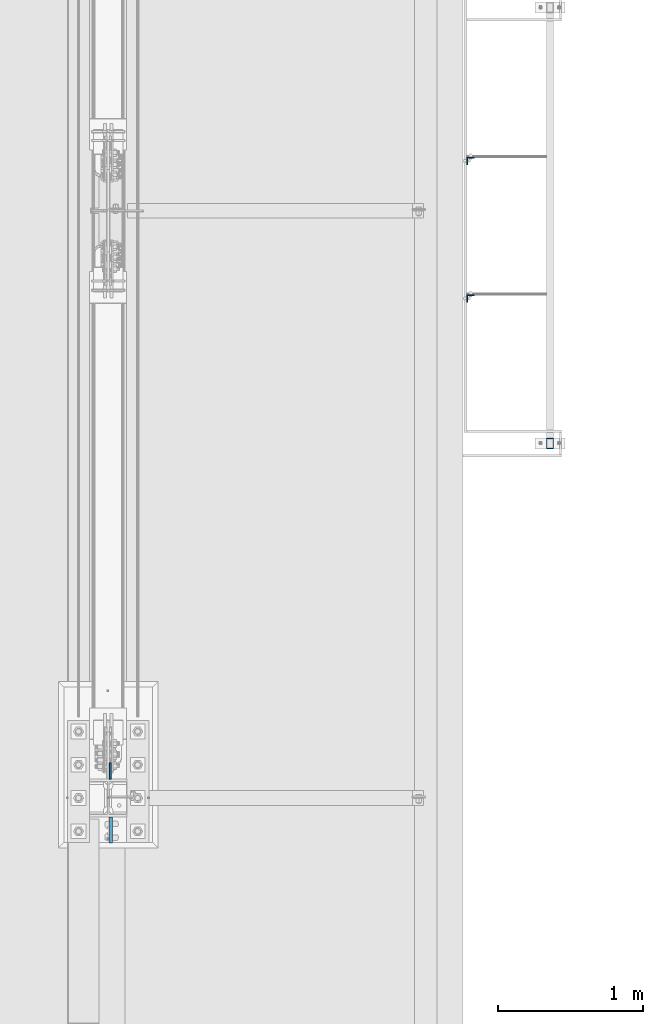
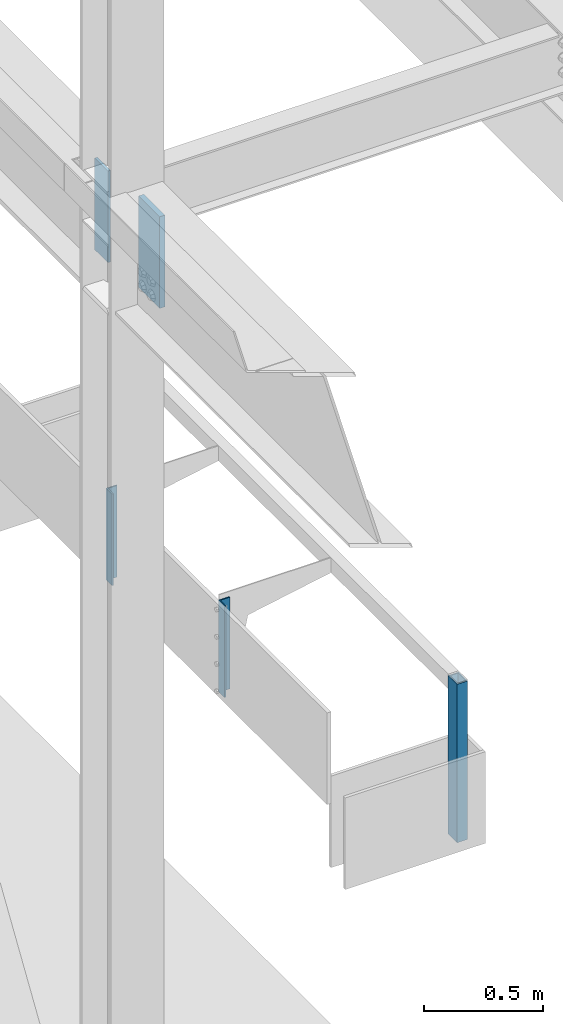
# One storey, part 1540 of 3843: 5 columns, 4 elements without a shape of their own.
"""IFC2X3 building model written with IfcOpenShell, lengths in millimetres."""

import ifcopenshell
import ifcopenshell.guid

model = None  # the IFC model being written
_history = None  # IfcOwnerHistory: only IFC2X3 demands one
_inside = {}  # id of a spatial element -> (the spatial element, [elements in it])
_under = {}  # id of a project, library or spatial element -> (it, [spatial elements below it])
_declared = {}  # id of a project -> (the project, [libraries it declares])
_typed = {}  # id of a type object -> (the type object, [elements of that type])
_made_of = {}  # id of a material, layer set ... -> (it, [elements and type objects made of it])


def new_model(schema):
    """Start an empty IFC model of exactly this schema.

    Asked for "IFC4X3", IfcOpenShell would pick the latest addendum, in which some entities
    have other attributes; the version numbers below select the first issue.
    IFC2X3 requires an IfcOwnerHistory on every rooted entity: one is made here for all.
    """
    global model, _history
    if schema == "IFC4X3":
        model = ifcopenshell.file(schema_version=(4, 3, 0, 0))
    else:
        model = ifcopenshell.file(schema=schema)
    _inside.clear()
    _under.clear()
    _declared.clear()
    _typed.clear()
    _made_of.clear()
    _history = None
    if model.schema == "IFC2X3":
        org = make("IfcOrganization", Name="unknown")
        user = make(
            "IfcPersonAndOrganization",
            ThePerson=make("IfcPerson", FamilyName="unknown"),
            TheOrganization=org,
        )
        app = make(
            "IfcApplication",
            ApplicationDeveloper=org,
            Version="unknown",
            ApplicationFullName="unknown",
            ApplicationIdentifier="unknown",
        )
        _history = make(
            "IfcOwnerHistory",
            OwningUser=user,
            OwningApplication=app,
            ChangeAction="ADDED",
            CreationDate=0,
        )
    return model


def make(cls, **values):
    """One entity of the class cls with the attributes given. An attribute that is None is left unset."""
    return model.create_entity(
        cls, **{name: value for name, value in values.items() if value is not None}
    )


def rooted(cls, **values):
    """An entity with a GlobalId (a new one), such as an element, a storey or a relation."""
    return make(cls, GlobalId=ifcopenshell.guid.new(), OwnerHistory=_history, **values)


def si_unit(unit_type, name, prefix=None):
    """IfcSIUnit, for example si_unit("LENGTHUNIT", "METRE", prefix="MILLI")."""
    return make("IfcSIUnit", UnitType=unit_type, Prefix=prefix, Name=name)


def assignment(units):
    """IfcUnitAssignment: the units of a project."""
    return None if units is None else make("IfcUnitAssignment", Units=units)


def point(xyz):
    """IfcCartesianPoint."""
    return None if xyz is None else make("IfcCartesianPoint", Coordinates=xyz)


def direction(xyz):
    """IfcDirection."""
    return None if xyz is None else make("IfcDirection", DirectionRatios=xyz)


def frame(location, z_axis=None, x_axis=None):
    """IfcAxis2Placement3D, a coordinate frame: its origin and axes. An axis left out is left unset."""
    return make(
        "IfcAxis2Placement3D",
        Location=point(location),
        Axis=direction(z_axis),
        RefDirection=direction(x_axis),
    )


def origin_with_axes():
    """The frame at (0, 0, 0) with the z axis (0, 0, 1) and the x axis (1, 0, 0) written out."""
    return frame((0.0, 0.0, 0.0), z_axis=(0.0, 0.0, 1.0), x_axis=(1.0, 0.0, 0.0))


def place(relative_to, where):
    """IfcLocalPlacement: puts the frame where relative to a parent placement (None: the world)."""
    return make(
        "IfcLocalPlacement", PlacementRelTo=relative_to, RelativePlacement=where
    )


def context(
    kind, dimensions, precision=None, world=None, true_north=None, identifier=None
):
    """IfcGeometricRepresentationContext, for example the 3D "Model" context."""
    return make(
        "IfcGeometricRepresentationContext",
        ContextIdentifier=identifier,
        ContextType=kind,
        CoordinateSpaceDimension=dimensions,
        Precision=precision,
        WorldCoordinateSystem=world,
        TrueNorth=true_north,
    )


def subcontext(parent, identifier, kind, view, scale=None):
    """IfcGeometricRepresentationSubContext, for example "Body" below "Model"."""
    return make(
        "IfcGeometricRepresentationSubContext",
        ContextIdentifier=identifier,
        ContextType=kind,
        ParentContext=parent,
        TargetScale=scale,
        TargetView=view,
    )


def project(units=None, contexts=None):
    """IfcProject with its units and contexts."""
    return rooted(
        "IfcProject",
        Name="project",
        RepresentationContexts=contexts,
        UnitsInContext=assignment(units),
    )


def spatial(cls, under=None, at=None, **own):
    """A site, building, storey or space (cls), placed at a placement, below another one or the project."""
    s = rooted(cls, ObjectPlacement=at, **own)
    if under is not None:
        _under.setdefault(under.id(), (under, []))[1].append(s)
    return s


def faces_of(points, faces, orient=None, outer=None):
    """IfcFace entities. A face is a list of loops; a loop is a list of indices into points, from 0.

    orient and outer hold one flag for each loop. By default every Orientation is true, the
    first loop of a face is its IfcFaceOuterBound and the others are IfcFaceBound.
    """
    made = []
    for i, loops in enumerate(faces):
        bounds = []
        for j, loop in enumerate(loops):
            is_outer = j == 0 if outer is None else outer[i][j]
            bounds.append(
                make(
                    "IfcFaceOuterBound" if is_outer else "IfcFaceBound",
                    Bound=make("IfcPolyLoop", Polygon=[points[k] for k in loop]),
                    Orientation=True if orient is None else orient[i][j],
                )
            )
        made.append(make("IfcFace", Bounds=bounds))
    return made


def faceted_brep(points, faces, orient=None, outer=None, voids=None):
    """IfcFacetedBrep: a solid bounded by flat faces; with voids (closed shells), ...WithVoids."""
    shared = [point(p) for p in points]
    hull = make("IfcClosedShell", CfsFaces=faces_of(shared, faces, orient, outer))
    if voids is None:
        return make("IfcFacetedBrep", Outer=hull)
    return make(
        "IfcFacetedBrepWithVoids",
        Outer=hull,
        Voids=[
            make(cls, CfsFaces=faces_of(shared, fs, o, b)) for cls, fs, o, b in voids
        ],
    )


def shape(context_of_items, identifier, shape_type, items):
    """IfcShapeRepresentation: the items that make up one representation, for example the "Body"."""
    return make(
        "IfcShapeRepresentation",
        ContextOfItems=context_of_items,
        RepresentationIdentifier=identifier,
        RepresentationType=shape_type,
        Items=items,
    )


def material(Name=None, Category=None):
    """IfcMaterial."""
    return make("IfcMaterial", Name=Name, Category=Category)


def made_of(thing, what):
    """Note that an element or type object is made of a material, layer set ...; save() writes the relation."""
    if what is not None:
        _made_of.setdefault(what.id(), (what, []))[1].append(thing)
    return thing


def type_object(cls, material=None, **own):
    """A type object (cls), such as IfcWallType, which elements share."""
    return made_of(rooted(cls, **own), material)


def element(
    cls,
    number,
    at=None,
    inside=None,
    cuts=None,
    type_object=None,
    material=None,
    context=None,
    identifier="Body",
    shape_type=None,
    held_by="IfcProductDefinitionShape",
    body=None,
    shapes=None,
    **own,
):
    """One element of the class cls, such as IfcWall. Its Tag is "e" and its number.

    at: its placement. inside: the storey or other place that contains it. cuts: it is an
    opening in that element (IfcRelVoidsElement). A single representation is given by context,
    identifier, shape_type and body (its items); several are given by shapes. held_by: the class
    of the entity that holds the representations. save() writes the other relations.
    """
    e = rooted(cls, Tag="e%d" % number, ObjectPlacement=at, **own)
    if body is not None:
        shapes = [shape(context, identifier, shape_type, body)]
    if shapes is not None:
        e.Representation = make(held_by, Representations=shapes)
    if inside is not None:
        _inside.setdefault(inside.id(), (inside, []))[1].append(e)
    if cuts is not None:
        rooted(
            "IfcRelVoidsElement", RelatingBuildingElement=cuts, RelatedOpeningElement=e
        )
    if type_object is not None:
        _typed.setdefault(type_object.id(), (type_object, []))[1].append(e)
    return made_of(e, material)


def aggregate(whole, parts):
    """IfcRelAggregates: a whole, such as a stair, and the parts it consists of."""
    return rooted("IfcRelAggregates", RelatingObject=whole, RelatedObjects=parts)


def save(model, path):
    """Write the relations noted so far, then the file.

    IfcRelAggregates (storeys below a building ...), IfcRelContainedInSpatialStructure (elements
    in a storey), IfcRelDefinesByType, IfcRelAssociatesMaterial and IfcRelDeclares: one each for
    every whole, place, type object, material and project.
    """
    for whole, parts in _under.values():
        aggregate(whole, parts)
    for where, things in _inside.values():
        rooted(
            "IfcRelContainedInSpatialStructure",
            RelatedElements=things,
            RelatingStructure=where,
        )
    for kind, things in _typed.values():
        rooted("IfcRelDefinesByType", RelatedObjects=things, RelatingType=kind)
    for what, things in _made_of.values():
        rooted("IfcRelAssociatesMaterial", RelatedObjects=things, RelatingMaterial=what)
    for by, libraries in _declared.values():
        rooted("IfcRelDeclares", RelatingContext=by, RelatedDefinitions=libraries)
    model.write(path)


model = new_model("IFC2X3")

# Units and contexts
model_context = context("Model", 3, precision=1e-05, world=origin_with_axes())
body_context = subcontext(model_context, "Body", "Model", "MODEL_VIEW")
ifc_project = project(units=[si_unit("LENGTHUNIT", "METRE", prefix="MILLI"), si_unit("AREAUNIT", "SQUARE_METRE"), si_unit("VOLUMEUNIT", "CUBIC_METRE"), si_unit("MASSUNIT", "GRAM", prefix="KILO"), si_unit("TIMEUNIT", "SECOND"), si_unit("PLANEANGLEUNIT", "RADIAN"), si_unit("SOLIDANGLEUNIT", "STERADIAN"), si_unit("THERMODYNAMICTEMPERATUREUNIT", "DEGREE_CELSIUS"), si_unit("LUMINOUSINTENSITYUNIT", "LUMEN")], contexts=[model_context])

# Site, building, storey
site_placement = place(None, origin_with_axes())
site = spatial("IfcSite", under=ifc_project, at=site_placement, CompositionType="ELEMENT")
building_placement = place(site_placement, origin_with_axes())
building = spatial("IfcBuilding", under=site, at=building_placement, Name="Undefined", CompositionType="ELEMENT")
storey_placement = place(building_placement, origin_with_axes())
storey = spatial("IfcBuildingStorey", under=building, at=storey_placement, Name="Undefined", CompositionType="ELEMENT", Elevation=0.0)

# Assembly, column
assembly_1_placement = place(storey_placement, origin_with_axes())
assembly_1 = element("IfcElementAssembly", 1, at=assembly_1_placement, inside=storey, Name="FRAME", AssemblyPlace="NOTDEFINED", PredefinedType="RIGID_FRAME")
ifc_material_1 = material()
column_type_1 = type_object("IfcColumnType", Name="HSS3X2X1/4", PredefinedType="NOTDEFINED")
column_1_placement = place(assembly_1_placement, frame((3038.078125, 98920.3, 30486.35), z_axis=(0.0, 1.0, 0.0), x_axis=(0.0, 0.0, 1.0)))
column_1 = element("IfcColumn", 2, at=column_1_placement, type_object=column_type_1, material=ifc_material_1, Name="POST", ObjectType="HSS3X2X1/4", context=body_context, shape_type="Brep", body=[
    faceted_brep([(0.0, 19.0500000000029, -31.75), (0.0, -19.0500000000029, -31.75), (812.800000000007, -19.0500000000029, -31.75), (812.800000000007, 19.0500000000029, -31.75), (0.0, -19.0500000000029, 31.75), (812.800000000007, -19.0500000000029, 31.75), (0.0, 19.0500000000029, 31.75), (812.800000000007, 19.0500000000029, 31.75), (0.0, 25.4000000000015, -38.0999999999985), (0.0, 25.4000000000015, 38.0999999999985), (812.800000000007, 25.4000000000015, 38.0999999999985), (812.800000000007, 25.4000000000015, -38.0999999999985), (0.0, -25.4000000000015, 38.0999999999985), (812.800000000007, -25.4000000000015, 38.0999999999985), (0.0, -25.4000000000015, -38.0999999999985), (812.800000000007, -25.4000000000015, -38.0999999999985)], [[[0, 1, 2, 3]], [[1, 4, 5, 2]], [[4, 6, 7, 5]], [[6, 0, 3, 7]], [[8, 9, 10, 11]], [[9, 12, 13, 10]], [[12, 14, 15, 13]], [[14, 8, 11, 15]], [[13, 15, 11, 10], [5, 7, 3, 2]], [[14, 12, 9, 8], [6, 4, 1, 0]]]),
])
aggregate(assembly_1, [column_1])

assembly_2_placement = place(storey_placement, origin_with_axes())
assembly_2 = element("IfcElementAssembly", 3, at=assembly_2_placement, inside=storey, Name="ANGLE", AssemblyPlace="NOTDEFINED", PredefinedType="RIGID_FRAME")
ifc_material_2 = material(Name="STEEL/A572-50")
column_type_2 = type_object("IfcColumnType", Name="L2X2X1/4", PredefinedType="NOTDEFINED")
column_2_placement = place(assembly_2_placement, frame((2492.375, 100863.400001, 30810.2), z_axis=(0.0, -1.0, 0.0), x_axis=(0.0, 0.0, 1.0)))
column_2 = element("IfcColumn", 4, at=column_2_placement, type_object=column_type_2, material=ifc_material_2, Name="ANGLE", ObjectType="L2X2X1/4", context=body_context, shape_type="Brep", body=[
    faceted_brep([(0.0, 25.4000000000015, -25.4000000000015), (0.0, 25.4000000000015, 25.4000000000015), (469.900000000001, 25.4000000000015, 25.4000000000015), (469.900000000001, 25.4000000000015, -25.4000000000015), (0.0, 19.0500000000029, 25.4000000000015), (469.900000000001, 19.0500000000029, 25.4000000000015), (0.0, 19.0500000000029, -19.0499999999993), (469.900000000001, 19.0500000000029, -19.0499999999993), (0.0, -25.4000000000015, -19.0499999999993), (469.900000000001, -25.4000000000015, -19.0499999999993), (0.0, -25.4000000000015, -25.4000000000015), (469.900000000001, -25.4000000000015, -25.4000000000015)], [[[0, 1, 2, 3]], [[1, 4, 5, 2]], [[4, 6, 7, 5]], [[6, 8, 9, 7]], [[8, 10, 11, 9]], [[10, 0, 3, 11]], [[5, 7, 9, 11, 3, 2]], [[10, 8, 6, 4, 1, 0]]]),
])
aggregate(assembly_2, [column_2])

assembly_3_placement = place(storey_placement, origin_with_axes())
assembly_3 = element("IfcElementAssembly", 5, at=assembly_3_placement, inside=storey, Name="ANGLE", AssemblyPlace="NOTDEFINED", PredefinedType="RIGID_FRAME")
column_3_placement = place(assembly_3_placement, frame((2492.375, 99917.25, 30810.2), z_axis=(0.0, -1.0, 0.0), x_axis=(0.0, 0.0, 1.0)))
column_3 = element("IfcColumn", 6, at=column_3_placement, type_object=column_type_2, material=ifc_material_2, Name="ANGLE", ObjectType="L2X2X1/4", context=body_context, shape_type="Brep", body=[
    faceted_brep([(0.0, 25.4000000000015, -25.4000000000015), (0.0, 25.4000000000015, 25.4000000000015), (469.900000000001, 25.4000000000015, 25.4000000000015), (469.900000000001, 25.4000000000015, -25.4000000000015), (0.0, 19.0500000000029, 25.4000000000015), (469.900000000001, 19.0500000000029, 25.4000000000015), (0.0, 19.0500000000029, -19.0499999999993), (469.900000000001, 19.0500000000029, -19.0499999999993), (0.0, -25.4000000000015, -19.0499999999993), (469.900000000001, -25.4000000000015, -19.0499999999993), (0.0, -25.4000000000015, -25.4000000000015), (469.900000000001, -25.4000000000015, -25.4000000000015)], [[[0, 1, 2, 3]], [[1, 4, 5, 2]], [[4, 6, 7, 5]], [[6, 8, 9, 7]], [[8, 10, 11, 9]], [[10, 0, 3, 11]], [[5, 7, 9, 11, 3, 2]], [[10, 8, 6, 4, 1, 0]]]),
])
aggregate(assembly_3, [column_3])

# Assembly, columns
assembly_4_placement = place(storey_placement, origin_with_axes())
assembly_4 = element("IfcElementAssembly", 7, at=assembly_4_placement, inside=storey, Name="COLUMN", AssemblyPlace="NOTDEFINED", PredefinedType="RIGID_FRAME")
column_type_3 = type_object("IfcColumnType", PredefinedType="NOTDEFINED")
column_4_placement = place(assembly_4_placement, frame((13.493000125885, 96667.6375, 35890.2), z_axis=(0.0, -1.0, 0.0), x_axis=(0.0, 0.0, 1.0)))
column_4 = element("IfcColumn", 8, at=column_4_placement, type_object=column_type_3, material=ifc_material_2, Name="PLATE", context=body_context, shape_type="Brep", body=[
    faceted_brep([(0.0, 6.35000000000582, -55.5625), (0.0, 6.35000000000582, 55.5625), (469.899999999994, 6.35000000000582, 55.5625), (469.899999999994, 6.35000000000582, -55.5625), (0.0, -6.35000000000582, 55.5625), (469.899999999994, -6.35000000000582, 55.5625), (0.0, -6.35000000000582, -55.5625), (469.899999999994, -6.35000000000582, -55.5625)], [[[0, 1, 2, 3]], [[1, 4, 5, 2]], [[4, 6, 7, 5]], [[6, 0, 3, 7]], [[5, 7, 3, 2]], [[6, 4, 1, 0]]]),
])
column_type_4 = type_object("IfcColumnType", PredefinedType="NOTDEFINED")
column_5_placement = place(assembly_4_placement, frame((18.2560002326965, 96262.825, 35921.95), z_axis=(0.0, 1.0, 0.0), x_axis=(0.0, 0.0, 1.0)))
column_5 = element("IfcColumn", 9, at=column_5_placement, type_object=column_type_4, material=ifc_material_2, Name="PLATE", context=body_context, shape_type="Brep", body=[
    faceted_brep([(0.0, 12.6999999999971, -88.9000000000015), (0.0, 12.7000000000007, 88.9000015258789), (469.900000000001, 12.6999999999971, 88.9000000000015), (469.900000000001, 12.6999999999971, -88.9000000000015), (0.0, -12.7000000000007, 88.9000015258789), (469.900000000001, -12.6999999999971, 88.9000000000015), (0.0, -12.6999999999971, -88.9000000000015), (469.900000000001, -12.6999999999971, -88.9000000000015)], [[[0, 1, 2, 3]], [[1, 4, 5, 2]], [[4, 6, 7, 5]], [[6, 0, 3, 7]], [[5, 7, 3, 2]], [[6, 4, 1, 0]]]),
])
aggregate(assembly_4, [column_4, column_5])

save(model, "model.ifc")
